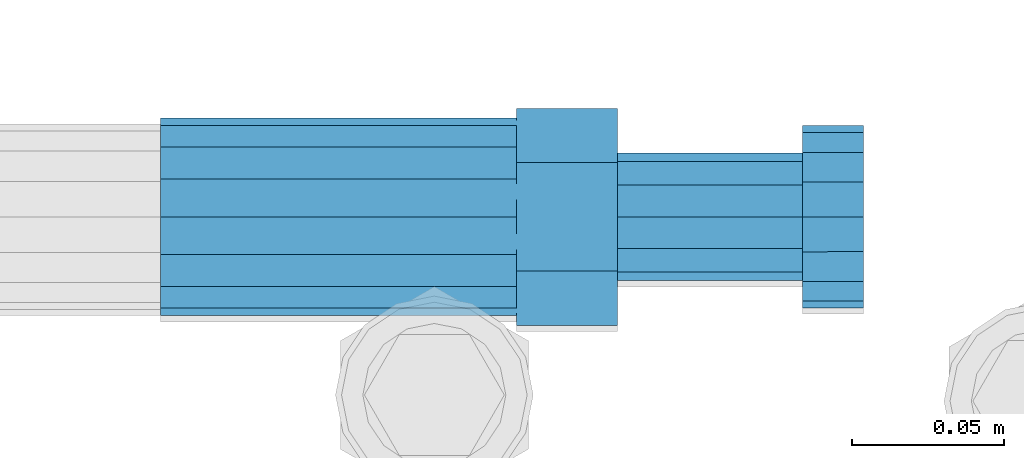
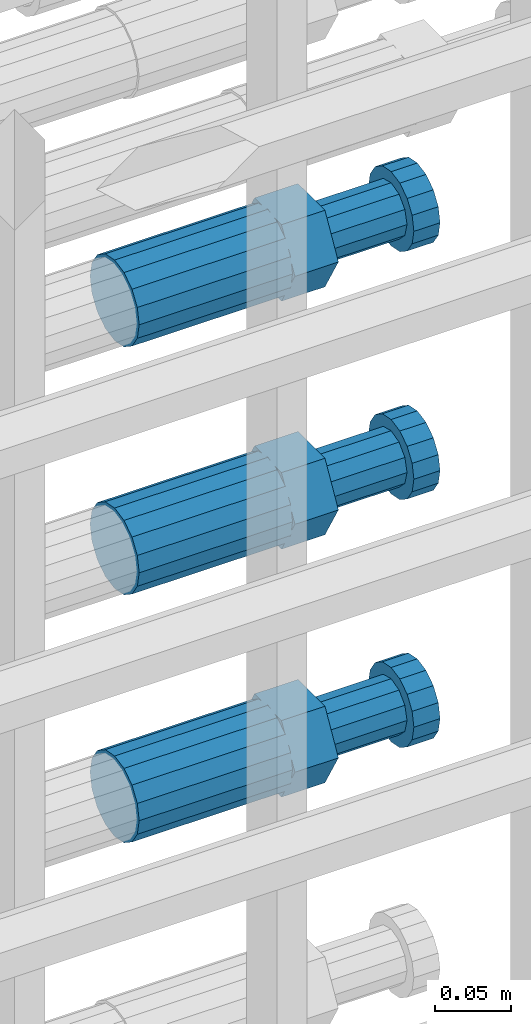
# One storey, part 100 of 119: 3 beams.
"""IFC2X3 building model written with IfcOpenShell, lengths in millimetres."""

from ifc_helpers import new_model, si_unit, frame, origin_with_axes, place, context, subcontext, project, spatial, faceted_brep, material, type_object, element, save


model = new_model("IFC2X3")

# Units and contexts
model_context = context("Model", 3, precision=1e-05, world=origin_with_axes())
body_context = subcontext(model_context, "Body", "Model", "MODEL_VIEW")
ifc_project = project(units=[si_unit("LENGTHUNIT", "METRE", prefix="MILLI"), si_unit("AREAUNIT", "SQUARE_METRE"), si_unit("VOLUMEUNIT", "CUBIC_METRE"), si_unit("MASSUNIT", "GRAM", prefix="KILO"), si_unit("TIMEUNIT", "SECOND"), si_unit("PLANEANGLEUNIT", "RADIAN"), si_unit("SOLIDANGLEUNIT", "STERADIAN"), si_unit("THERMODYNAMICTEMPERATUREUNIT", "DEGREE_CELSIUS"), si_unit("LUMINOUSINTENSITYUNIT", "LUMEN")], contexts=[model_context])

# Site, building, storey
site_placement = place(None, origin_with_axes())
site = spatial("IfcSite", under=ifc_project, at=site_placement, CompositionType="ELEMENT")
building_placement = place(site_placement, origin_with_axes())
building = spatial("IfcBuilding", under=site, at=building_placement, Name="Undefined", CompositionType="ELEMENT")
storey_placement = place(building_placement, origin_with_axes())
storey = spatial("IfcBuildingStorey", under=building, at=storey_placement, Name="Undefined", CompositionType="ELEMENT", Elevation=0.0)

# Beams
ifc_material = material(Name="STEEL/S275")
beam_type = type_object("IfcBeamType", Name="ROD65", PredefinedType="NOTDEFINED")
beam_1_placement = place(storey_placement, frame((2038739.00023304, 6205214.98994599, 21908.9894219673), z_axis=(0.0, 0.0, 1.0), x_axis=(1.0, 0.0, 0.0)))
element("IfcBeam", 1, at=beam_1_placement, inside=storey, type_object=beam_type, material=ifc_material, Name="AGB40", ObjectType="ROD65", context=body_context, shape_type="Brep", body=[
    faceted_brep([(116.999999999069, 17.8249999252148, 30.8738056446964), (116.999999998137, 22.0056957420893, 23.632628078838), (116.999999999069, 12.4372115600854, 30.0260848066173), (116.999999999069, 8.17543111252598, 30.8738056446964), (117.000000000931, -17.8250000746921, 30.8738056446964), (150.200000001118, -17.8250000723638, 30.8738056446964), (150.199999999255, 17.8249999275431, 30.8738056446964), (117.000000000931, -8.17543109622784, 30.8738056446964), (117.000000001863, -22.0056959956419, 23.6326278985034), (117.000000000931, -12.4372115437873, 30.0260848066173), (117.000000001863, -35.6500000746455, -2.18278728425503e-10), (150.200000002049, -35.6500000723172, -2.18278728425503e-10), (117.000000001863, -30.8443149488885, 8.32369080289209), (117.000000001863, -30.8443149488885, -8.32369080355784), (117.000000002794, -32.4999999918509, 0.0), (117.000000000931, -17.8250000746921, -30.873805645133), (150.200000001118, -17.8250000723638, -30.873805645133), (117.000000001863, -22.0056959961075, -23.6326278982269), (117.000000000931, -8.17543109389953, -30.873805645133), (117.000000000931, -12.4372115437873, -30.0260848066173), (116.999999999069, 17.8249999252148, -30.873805645133), (150.199999999255, 17.8249999275431, -30.873805645133), (116.999999999069, 8.17543111019768, -30.873805645133), (116.999999999069, 12.4372115600854, -30.0260848066173), (116.999999998137, 22.005695742555, -23.6326280785652), (116.999999998137, 35.6499999251682, -2.18278728425503e-10), (150.199999998324, 35.6499999277294, -2.18278728425503e-10), (116.999999998137, 30.8443150522653, -8.32369036550881), (116.999999997206, 32.5000000081491, 0.0), (116.999999998137, 30.8443150522653, 8.32369036483942), (1.86264514923096e-09, -22.9809703885112, 22.9809703885621), (1.86264514923096e-09, -30.0260848065373, 12.4372115518672), (117.000000001863, -30.0260847983882, 12.4372115518672), (117.000000001863, -22.9809703803621, 22.9809703885621), (-1.86264514923096e-09, 22.9809703885112, -22.9809703885621), (-1.86264514923096e-09, 30.0260848065373, -12.4372115518672), (116.999999998137, 30.0260848146863, -12.4372115518672), (116.999999998137, 22.9809703966603, -22.9809703885621), (1.86264514923096e-09, -30.0260848065373, -12.4372115518672), (1.86264514923096e-09, -22.9809703885112, -22.9809703885621), (117.000000001863, -22.9809703803621, -22.9809703885621), (117.000000001863, -30.0260847983882, -12.4372115518672), (9.31322574615479e-10, -12.4372115519363, 30.0260848066173), (0.0, 0.0, 32.5), (-9.31322574615479e-10, 12.4372115519363, 30.0260848066173), (-1.86264514923096e-09, 22.9809703885112, 22.9809703885621), (-1.86264514923096e-09, 30.0260848065373, 12.4372115518672), (-2.79396772384644e-09, 32.5, 0.0), (-9.31322574615479e-10, 12.4372115519363, -30.0260848066173), (0.0, 0.0, -32.5), (9.31322574615479e-10, -12.4372115519363, -30.0260848066173), (2.79396772384644e-09, -32.5, 0.0), (116.999999998137, 22.9809703966603, 22.9809703885621), (116.999999998137, 30.0260848146863, 12.4372115518672), (117.0, 8.14907252788544e-09, -32.5), (117.0, 8.14907252788544e-09, 32.5), (150.200000000186, -10.5000000959262, 18.1865334791873), (150.199999999255, -9.59262251853943e-08, 20.9999999997126), (150.199999998324, 10.4999999040738, 18.1865334791873), (150.199999997392, 18.1865333835594, 10.4999999997126), (150.199999997392, 20.9999999040738, -2.87400325760245e-10), (150.199999997392, 18.1865333835594, -10.5000000002874), (150.199999998324, 10.4999999040738, -18.1865334797621), (150.199999999255, -9.59262251853943e-08, -21.0000000002874), (150.200000000186, -10.5000000959262, -18.1865334797621), (150.200000000186, -18.1865335754119, -10.5000000002874), (150.200000001118, -21.0000000959262, -2.87400325760245e-10), (150.200000000186, -18.1865335754119, 10.4999999997126), (210.979999999516, 10.4999999082647, 18.1865334791873), (210.979999999516, -9.17352735996246e-08, 20.9999999997126), (210.979999997653, 18.1865333877504, 10.4999999997126), (210.979999997653, 20.9999999082647, -2.87400325760245e-10), (210.979999997653, 18.1865333877504, -10.5000000002874), (210.979999999516, 10.4999999082647, -18.1865334797621), (210.979999999516, -9.17352735996246e-08, -21.0000000002874), (210.979999999516, -10.5000000917353, -18.1865334797621), (210.980000000447, -18.1865335712209, -10.5000000002874), (210.980000001378, -21.0000000917353, -2.87400325760245e-10), (210.980000000447, -18.1865335712209, 10.4999999997126), (210.979999999516, -10.5000000917353, 18.1865334791873), (211.001368402503, -27.7269939335529, -11.4911163272045), (211.003082515672, -21.2238095656503, -21.2238154190527), (231.002518340945, -21.2131946226582, -21.2132004554769), (231.000804228708, -27.7163789905608, -11.4805013636287), (211.001368415542, -11.4911086384673, -27.7269970399575), (231.000804241747, -11.4804936954752, -27.7163820763781), (210.996487061493, -0.0106066407170147, -30.0106107396168), (230.995922887698, 8.30227509140968e-06, -29.999995776041), (210.98918159306, 11.4698940692469, -27.7269970332745), (230.988617419265, 11.4805090120062, -27.7163820696951), (210.980564201251, 21.2025913291145, -21.2238154067054), (230.980000027455, 21.2132062721066, -21.2132004431296), (210.971946807578, 27.7057702087332, -11.4911163110701), (230.971382633783, 27.7163851517253, -11.4805013474943), (210.964641331695, 29.9893806746695, -0.0106149565435771), (230.9640771579, 29.9999956176616, 7.03221303410828e-09), (210.959759964608, 27.7057637346443, 11.4698863966551), (230.959195790812, 27.7163786776364, 11.4805013602345), (210.958045851439, 21.2025793667417, 21.2025854885032), (230.957481677644, 21.2131943097338, 21.2132004520827), (210.959759951569, 11.4698784395587, 27.705767109408), (230.959195776843, 11.4804933823179, 27.7163820729838), (210.964641305618, -0.0106235581915826, 29.9893808090674), (230.964077131823, -8.61519947648048e-06, 29.9999957726432), (210.971946774051, -11.4911242681555, 27.7057671027251), (230.971382599324, -11.4805093251634, 27.7163820663009), (210.98056416586, -21.2238215280231, 21.2025854761559), (230.979999991134, -21.2132065852638, 21.2132004397354), (210.989181559533, -27.7270004076418, 11.4698863805206), (230.988617384806, -27.7163854646496, 11.4805013441), (210.996487035416, -30.0106108735781, -0.0106149740058754), (230.995922861621, -29.999995930586, -1.04300852399319e-08)], [[[0, 1, 2, 3]], [[4, 5, 6, 0, 3, 7]], [[8, 4, 7, 9]], [[10, 11, 5, 4, 8, 12]], [[13, 10, 12, 14]], [[15, 16, 11, 10, 13, 17]], [[18, 15, 17, 19]], [[20, 21, 16, 15, 18, 22]], [[20, 22, 23, 24]], [[25, 26, 21, 20, 24, 27]], [[25, 27, 28, 29]], [[30, 31, 32, 33]], [[34, 35, 36, 37]], [[38, 39, 40, 41]], [[31, 30, 42, 43, 44, 45, 46, 47, 35, 34, 48, 49, 50, 39, 38, 51]], [[46, 45, 52, 53]], [[28, 47, 46, 53, 29]], [[27, 36, 35, 47, 28]], [[24, 37, 36, 27]], [[23, 48, 34, 37, 24]], [[22, 54, 49, 48, 23]], [[18, 54, 22]], [[19, 50, 49, 54, 18]], [[17, 40, 39, 50, 19]], [[13, 41, 40, 17]], [[14, 51, 38, 41, 13]], [[12, 32, 31, 51, 14]], [[8, 33, 32, 12]], [[9, 42, 30, 33, 8]], [[7, 55, 43, 42, 9]], [[3, 55, 7]], [[2, 44, 43, 55, 3]], [[1, 52, 45, 44, 2]], [[29, 53, 52, 1]], [[0, 6, 26, 25, 29, 1]], [[5, 11, 16, 21, 26, 6], [56, 57, 58, 59, 60, 61, 62, 63, 64, 65, 66, 67]], [[68, 58, 57, 69]], [[70, 59, 58, 68]], [[71, 60, 59, 70]], [[72, 61, 60, 71]], [[73, 62, 61, 72]], [[74, 63, 62, 73]], [[75, 64, 63, 74]], [[76, 65, 64, 75]], [[77, 66, 65, 76]], [[78, 67, 66, 77]], [[79, 56, 67, 78]], [[69, 57, 56, 79]], [[80, 81, 82, 83]], [[81, 84, 85, 82]], [[84, 86, 87, 85]], [[86, 88, 89, 87]], [[88, 90, 91, 89]], [[90, 92, 93, 91]], [[92, 94, 95, 93]], [[94, 96, 97, 95]], [[96, 98, 99, 97]], [[98, 100, 101, 99]], [[100, 102, 103, 101]], [[102, 104, 105, 103]], [[104, 106, 107, 105]], [[106, 108, 109, 107]], [[108, 110, 111, 109]], [[82, 85, 87, 89, 91, 93, 95, 97, 99, 101, 103, 105, 107, 109, 111, 83]], [[110, 80, 83, 111]], [[108, 106, 104, 102, 100, 98, 96, 94, 92, 90, 88, 86, 84, 81, 80, 110], [78, 77, 76, 75, 74, 73, 72, 71, 70, 68, 69, 79]]]),
])
beam_2_placement = place(storey_placement, frame((2038739.00023304, 6205214.98994599, 21708.9894219673), z_axis=(0.0, 0.0, 1.0), x_axis=(1.0, 0.0, 0.0)))
element("IfcBeam", 2, at=beam_2_placement, inside=storey, type_object=beam_type, material=ifc_material, Name="AGB40", ObjectType="ROD65", context=body_context, shape_type="Brep", body=[
    faceted_brep([(116.999999999069, 17.8249999252148, 30.8738056446964), (116.999999998137, 22.0056957420893, 23.632628078838), (116.999999999069, 12.4372115600854, 30.0260848066173), (116.999999999069, 8.17543111252598, 30.8738056446964), (117.000000000931, -17.8250000746921, 30.8738056446964), (150.200000001118, -17.8250000723638, 30.8738056446964), (150.199999999255, 17.8249999275431, 30.8738056446964), (117.000000000931, -8.17543109622784, 30.8738056446964), (117.000000001863, -22.0056959956419, 23.6326278985034), (117.000000000931, -12.4372115437873, 30.0260848066173), (117.000000001863, -35.6500000746455, -2.18278728425503e-10), (150.200000002049, -35.6500000723172, -2.18278728425503e-10), (117.000000001863, -30.8443149488885, 8.32369080289209), (117.000000001863, -30.8443149488885, -8.32369080355784), (117.000000002794, -32.4999999918509, 0.0), (117.000000000931, -17.8250000746921, -30.873805645133), (150.200000001118, -17.8250000723638, -30.873805645133), (117.000000001863, -22.0056959961075, -23.6326278982269), (117.000000000931, -8.17543109389953, -30.873805645133), (117.000000000931, -12.4372115437873, -30.0260848066173), (116.999999999069, 17.8249999252148, -30.873805645133), (150.199999999255, 17.8249999275431, -30.873805645133), (116.999999999069, 8.17543111019768, -30.873805645133), (116.999999999069, 12.4372115600854, -30.0260848066173), (116.999999998137, 22.005695742555, -23.6326280785652), (116.999999998137, 35.6499999251682, -2.18278728425503e-10), (150.199999998324, 35.6499999277294, -2.18278728425503e-10), (116.999999998137, 30.8443150522653, -8.32369036550881), (116.999999997206, 32.5000000081491, 0.0), (116.999999998137, 30.8443150522653, 8.32369036483942), (1.86264514923096e-09, -22.9809703885112, 22.9809703885621), (1.86264514923096e-09, -30.0260848065373, 12.4372115518672), (117.000000001863, -30.0260847983882, 12.4372115518672), (117.000000001863, -22.9809703803621, 22.9809703885621), (-1.86264514923096e-09, 22.9809703885112, -22.9809703885621), (-1.86264514923096e-09, 30.0260848065373, -12.4372115518672), (116.999999998137, 30.0260848146863, -12.4372115518672), (116.999999998137, 22.9809703966603, -22.9809703885621), (1.86264514923096e-09, -30.0260848065373, -12.4372115518672), (1.86264514923096e-09, -22.9809703885112, -22.9809703885621), (117.000000001863, -22.9809703803621, -22.9809703885621), (117.000000001863, -30.0260847983882, -12.4372115518672), (9.31322574615479e-10, -12.4372115519363, 30.0260848066173), (0.0, 0.0, 32.5), (-9.31322574615479e-10, 12.4372115519363, 30.0260848066173), (-1.86264514923096e-09, 22.9809703885112, 22.9809703885621), (-1.86264514923096e-09, 30.0260848065373, 12.4372115518672), (-2.79396772384644e-09, 32.5, 0.0), (-9.31322574615479e-10, 12.4372115519363, -30.0260848066173), (0.0, 0.0, -32.5), (9.31322574615479e-10, -12.4372115519363, -30.0260848066173), (2.79396772384644e-09, -32.5, 0.0), (116.999999998137, 22.9809703966603, 22.9809703885621), (116.999999998137, 30.0260848146863, 12.4372115518672), (117.0, 8.14907252788544e-09, -32.5), (117.0, 8.14907252788544e-09, 32.5), (150.200000000186, -10.5000000959262, 18.1865334791873), (150.199999999255, -9.59262251853943e-08, 20.9999999997126), (150.199999998324, 10.4999999040738, 18.1865334791873), (150.199999997392, 18.1865333835594, 10.4999999997126), (150.199999997392, 20.9999999040738, -2.87400325760245e-10), (150.199999997392, 18.1865333835594, -10.5000000002874), (150.199999998324, 10.4999999040738, -18.1865334797621), (150.199999999255, -9.59262251853943e-08, -21.0000000002874), (150.200000000186, -10.5000000959262, -18.1865334797621), (150.200000000186, -18.1865335754119, -10.5000000002874), (150.200000001118, -21.0000000959262, -2.87400325760245e-10), (150.200000000186, -18.1865335754119, 10.4999999997126), (210.979999999516, 10.4999999082647, 18.1865334791873), (210.979999999516, -9.17352735996246e-08, 20.9999999997126), (210.979999997653, 18.1865333877504, 10.4999999997126), (210.979999997653, 20.9999999082647, -2.87400325760245e-10), (210.979999997653, 18.1865333877504, -10.5000000002874), (210.979999999516, 10.4999999082647, -18.1865334797621), (210.979999999516, -9.17352735996246e-08, -21.0000000002874), (210.979999999516, -10.5000000917353, -18.1865334797621), (210.980000000447, -18.1865335712209, -10.5000000002874), (210.980000001378, -21.0000000917353, -2.87400325760245e-10), (210.980000000447, -18.1865335712209, 10.4999999997126), (210.979999999516, -10.5000000917353, 18.1865334791873), (211.001368402503, -27.7269939335529, -11.4911163272045), (211.003082515672, -21.2238095656503, -21.2238154190527), (231.002518340945, -21.2131946226582, -21.2132004554769), (231.000804228708, -27.7163789905608, -11.4805013636287), (211.001368415542, -11.4911086384673, -27.7269970399575), (231.000804241747, -11.4804936954752, -27.7163820763781), (210.996487061493, -0.0106066407170147, -30.0106107396168), (230.995922887698, 8.30227509140968e-06, -29.999995776041), (210.98918159306, 11.4698940692469, -27.7269970332745), (230.988617419265, 11.4805090120062, -27.7163820696951), (210.980564201251, 21.2025913291145, -21.2238154067054), (230.980000027455, 21.2132062721066, -21.2132004431296), (210.971946807578, 27.7057702087332, -11.4911163110701), (230.971382633783, 27.7163851517253, -11.4805013474943), (210.964641331695, 29.9893806746695, -0.0106149565435771), (230.9640771579, 29.9999956176616, 7.03221303410828e-09), (210.959759964608, 27.7057637346443, 11.4698863966551), (230.959195790812, 27.7163786776364, 11.4805013602345), (210.958045851439, 21.2025793667417, 21.2025854885032), (230.957481677644, 21.2131943097338, 21.2132004520827), (210.959759951569, 11.4698784395587, 27.705767109408), (230.959195776843, 11.4804933823179, 27.7163820729838), (210.964641305618, -0.0106235581915826, 29.9893808090674), (230.964077131823, -8.61519947648048e-06, 29.9999957726432), (210.971946774051, -11.4911242681555, 27.7057671027251), (230.971382599324, -11.4805093251634, 27.7163820663009), (210.98056416586, -21.2238215280231, 21.2025854761559), (230.979999991134, -21.2132065852638, 21.2132004397354), (210.989181559533, -27.7270004076418, 11.4698863805206), (230.988617384806, -27.7163854646496, 11.4805013441), (210.996487035416, -30.0106108735781, -0.0106149740058754), (230.995922861621, -29.999995930586, -1.04300852399319e-08)], [[[0, 1, 2, 3]], [[4, 5, 6, 0, 3, 7]], [[8, 4, 7, 9]], [[10, 11, 5, 4, 8, 12]], [[13, 10, 12, 14]], [[15, 16, 11, 10, 13, 17]], [[18, 15, 17, 19]], [[20, 21, 16, 15, 18, 22]], [[20, 22, 23, 24]], [[25, 26, 21, 20, 24, 27]], [[25, 27, 28, 29]], [[30, 31, 32, 33]], [[34, 35, 36, 37]], [[38, 39, 40, 41]], [[31, 30, 42, 43, 44, 45, 46, 47, 35, 34, 48, 49, 50, 39, 38, 51]], [[46, 45, 52, 53]], [[28, 47, 46, 53, 29]], [[27, 36, 35, 47, 28]], [[24, 37, 36, 27]], [[23, 48, 34, 37, 24]], [[22, 54, 49, 48, 23]], [[18, 54, 22]], [[19, 50, 49, 54, 18]], [[17, 40, 39, 50, 19]], [[13, 41, 40, 17]], [[14, 51, 38, 41, 13]], [[12, 32, 31, 51, 14]], [[8, 33, 32, 12]], [[9, 42, 30, 33, 8]], [[7, 55, 43, 42, 9]], [[3, 55, 7]], [[2, 44, 43, 55, 3]], [[1, 52, 45, 44, 2]], [[29, 53, 52, 1]], [[0, 6, 26, 25, 29, 1]], [[5, 11, 16, 21, 26, 6], [56, 57, 58, 59, 60, 61, 62, 63, 64, 65, 66, 67]], [[68, 58, 57, 69]], [[70, 59, 58, 68]], [[71, 60, 59, 70]], [[72, 61, 60, 71]], [[73, 62, 61, 72]], [[74, 63, 62, 73]], [[75, 64, 63, 74]], [[76, 65, 64, 75]], [[77, 66, 65, 76]], [[78, 67, 66, 77]], [[79, 56, 67, 78]], [[69, 57, 56, 79]], [[80, 81, 82, 83]], [[81, 84, 85, 82]], [[84, 86, 87, 85]], [[86, 88, 89, 87]], [[88, 90, 91, 89]], [[90, 92, 93, 91]], [[92, 94, 95, 93]], [[94, 96, 97, 95]], [[96, 98, 99, 97]], [[98, 100, 101, 99]], [[100, 102, 103, 101]], [[102, 104, 105, 103]], [[104, 106, 107, 105]], [[106, 108, 109, 107]], [[108, 110, 111, 109]], [[82, 85, 87, 89, 91, 93, 95, 97, 99, 101, 103, 105, 107, 109, 111, 83]], [[110, 80, 83, 111]], [[108, 106, 104, 102, 100, 98, 96, 94, 92, 90, 88, 86, 84, 81, 80, 110], [78, 77, 76, 75, 74, 73, 72, 71, 70, 68, 69, 79]]]),
])
beam_3_placement = place(storey_placement, frame((2038739.00023304, 6205214.98994599, 21508.9894219673), z_axis=(0.0, 0.0, 1.0), x_axis=(1.0, 0.0, 0.0)))
element("IfcBeam", 3, at=beam_3_placement, inside=storey, type_object=beam_type, material=ifc_material, Name="AGB40", ObjectType="ROD65", context=body_context, shape_type="Brep", body=[
    faceted_brep([(116.999999999069, 17.8249999252148, 30.8738056446964), (116.999999998137, 22.0056957420893, 23.632628078838), (116.999999999069, 12.4372115600854, 30.0260848066173), (116.999999999069, 8.17543111252598, 30.8738056446964), (117.000000000931, -17.8250000746921, 30.8738056446964), (150.200000001118, -17.8250000723638, 30.8738056446964), (150.199999999255, 17.8249999275431, 30.8738056446964), (117.000000000931, -8.17543109622784, 30.8738056446964), (117.000000001863, -22.0056959956419, 23.6326278985034), (117.000000000931, -12.4372115437873, 30.0260848066173), (117.000000001863, -35.6500000746455, -2.18278728425503e-10), (150.200000002049, -35.6500000723172, -2.18278728425503e-10), (117.000000001863, -30.8443149488885, 8.32369080289209), (117.000000001863, -30.8443149488885, -8.32369080355784), (117.000000002794, -32.4999999918509, 0.0), (117.000000000931, -17.8250000746921, -30.873805645133), (150.200000001118, -17.8250000723638, -30.873805645133), (117.000000001863, -22.0056959961075, -23.6326278982269), (117.000000000931, -8.17543109389953, -30.873805645133), (117.000000000931, -12.4372115437873, -30.0260848066173), (116.999999999069, 17.8249999252148, -30.873805645133), (150.199999999255, 17.8249999275431, -30.873805645133), (116.999999999069, 8.17543111019768, -30.873805645133), (116.999999999069, 12.4372115600854, -30.0260848066173), (116.999999998137, 22.005695742555, -23.6326280785652), (116.999999998137, 35.6499999251682, -2.18278728425503e-10), (150.199999998324, 35.6499999277294, -2.18278728425503e-10), (116.999999998137, 30.8443150522653, -8.32369036550881), (116.999999997206, 32.5000000081491, 0.0), (116.999999998137, 30.8443150522653, 8.32369036483942), (1.86264514923096e-09, -22.9809703885112, 22.9809703885621), (1.86264514923096e-09, -30.0260848065373, 12.4372115518672), (117.000000001863, -30.0260847983882, 12.4372115518672), (117.000000001863, -22.9809703803621, 22.9809703885621), (-1.86264514923096e-09, 22.9809703885112, -22.9809703885621), (-1.86264514923096e-09, 30.0260848065373, -12.4372115518672), (116.999999998137, 30.0260848146863, -12.4372115518672), (116.999999998137, 22.9809703966603, -22.9809703885621), (1.86264514923096e-09, -30.0260848065373, -12.4372115518672), (1.86264514923096e-09, -22.9809703885112, -22.9809703885621), (117.000000001863, -22.9809703803621, -22.9809703885621), (117.000000001863, -30.0260847983882, -12.4372115518672), (9.31322574615479e-10, -12.4372115519363, 30.0260848066173), (0.0, 0.0, 32.5), (-9.31322574615479e-10, 12.4372115519363, 30.0260848066173), (-1.86264514923096e-09, 22.9809703885112, 22.9809703885621), (-1.86264514923096e-09, 30.0260848065373, 12.4372115518672), (-2.79396772384644e-09, 32.5, 0.0), (-9.31322574615479e-10, 12.4372115519363, -30.0260848066173), (0.0, 0.0, -32.5), (9.31322574615479e-10, -12.4372115519363, -30.0260848066173), (2.79396772384644e-09, -32.5, 0.0), (116.999999998137, 22.9809703966603, 22.9809703885621), (116.999999998137, 30.0260848146863, 12.4372115518672), (117.0, 8.14907252788544e-09, -32.5), (117.0, 8.14907252788544e-09, 32.5), (150.200000000186, -10.5000000959262, 18.1865334791873), (150.199999999255, -9.59262251853943e-08, 20.9999999997126), (150.199999998324, 10.4999999040738, 18.1865334791873), (150.199999997392, 18.1865333835594, 10.4999999997126), (150.199999997392, 20.9999999040738, -2.87400325760245e-10), (150.199999997392, 18.1865333835594, -10.5000000002874), (150.199999998324, 10.4999999040738, -18.1865334797621), (150.199999999255, -9.59262251853943e-08, -21.0000000002874), (150.200000000186, -10.5000000959262, -18.1865334797621), (150.200000000186, -18.1865335754119, -10.5000000002874), (150.200000001118, -21.0000000959262, -2.87400325760245e-10), (150.200000000186, -18.1865335754119, 10.4999999997126), (210.979999999516, 10.4999999082647, 18.1865334791873), (210.979999999516, -9.17352735996246e-08, 20.9999999997126), (210.979999997653, 18.1865333877504, 10.4999999997126), (210.979999997653, 20.9999999082647, -2.87400325760245e-10), (210.979999997653, 18.1865333877504, -10.5000000002874), (210.979999999516, 10.4999999082647, -18.1865334797621), (210.979999999516, -9.17352735996246e-08, -21.0000000002874), (210.979999999516, -10.5000000917353, -18.1865334797621), (210.980000000447, -18.1865335712209, -10.5000000002874), (210.980000001378, -21.0000000917353, -2.87400325760245e-10), (210.980000000447, -18.1865335712209, 10.4999999997126), (210.979999999516, -10.5000000917353, 18.1865334791873), (211.001368402503, -27.7269939335529, -11.4911163272045), (211.003082515672, -21.2238095656503, -21.2238154190527), (231.002518340945, -21.2131946226582, -21.2132004554769), (231.000804228708, -27.7163789905608, -11.4805013636287), (211.001368415542, -11.4911086384673, -27.7269970399575), (231.000804241747, -11.4804936954752, -27.7163820763781), (210.996487061493, -0.0106066407170147, -30.0106107396168), (230.995922887698, 8.30227509140968e-06, -29.999995776041), (210.98918159306, 11.4698940692469, -27.7269970332745), (230.988617419265, 11.4805090120062, -27.7163820696951), (210.980564201251, 21.2025913291145, -21.2238154067054), (230.980000027455, 21.2132062721066, -21.2132004431296), (210.971946807578, 27.7057702087332, -11.4911163110701), (230.971382633783, 27.7163851517253, -11.4805013474943), (210.964641331695, 29.9893806746695, -0.0106149565435771), (230.9640771579, 29.9999956176616, 7.03221303410828e-09), (210.959759964608, 27.7057637346443, 11.4698863966551), (230.959195790812, 27.7163786776364, 11.4805013602345), (210.958045851439, 21.2025793667417, 21.2025854885032), (230.957481677644, 21.2131943097338, 21.2132004520827), (210.959759951569, 11.4698784395587, 27.705767109408), (230.959195776843, 11.4804933823179, 27.7163820729838), (210.964641305618, -0.0106235581915826, 29.9893808090674), (230.964077131823, -8.61519947648048e-06, 29.9999957726432), (210.971946774051, -11.4911242681555, 27.7057671027251), (230.971382599324, -11.4805093251634, 27.7163820663009), (210.98056416586, -21.2238215280231, 21.2025854761559), (230.979999991134, -21.2132065852638, 21.2132004397354), (210.989181559533, -27.7270004076418, 11.4698863805206), (230.988617384806, -27.7163854646496, 11.4805013441), (210.996487035416, -30.0106108735781, -0.0106149740058754), (230.995922861621, -29.999995930586, -1.04300852399319e-08)], [[[0, 1, 2, 3]], [[4, 5, 6, 0, 3, 7]], [[8, 4, 7, 9]], [[10, 11, 5, 4, 8, 12]], [[13, 10, 12, 14]], [[15, 16, 11, 10, 13, 17]], [[18, 15, 17, 19]], [[20, 21, 16, 15, 18, 22]], [[20, 22, 23, 24]], [[25, 26, 21, 20, 24, 27]], [[25, 27, 28, 29]], [[30, 31, 32, 33]], [[34, 35, 36, 37]], [[38, 39, 40, 41]], [[31, 30, 42, 43, 44, 45, 46, 47, 35, 34, 48, 49, 50, 39, 38, 51]], [[46, 45, 52, 53]], [[28, 47, 46, 53, 29]], [[27, 36, 35, 47, 28]], [[24, 37, 36, 27]], [[23, 48, 34, 37, 24]], [[22, 54, 49, 48, 23]], [[18, 54, 22]], [[19, 50, 49, 54, 18]], [[17, 40, 39, 50, 19]], [[13, 41, 40, 17]], [[14, 51, 38, 41, 13]], [[12, 32, 31, 51, 14]], [[8, 33, 32, 12]], [[9, 42, 30, 33, 8]], [[7, 55, 43, 42, 9]], [[3, 55, 7]], [[2, 44, 43, 55, 3]], [[1, 52, 45, 44, 2]], [[29, 53, 52, 1]], [[0, 6, 26, 25, 29, 1]], [[5, 11, 16, 21, 26, 6], [56, 57, 58, 59, 60, 61, 62, 63, 64, 65, 66, 67]], [[68, 58, 57, 69]], [[70, 59, 58, 68]], [[71, 60, 59, 70]], [[72, 61, 60, 71]], [[73, 62, 61, 72]], [[74, 63, 62, 73]], [[75, 64, 63, 74]], [[76, 65, 64, 75]], [[77, 66, 65, 76]], [[78, 67, 66, 77]], [[79, 56, 67, 78]], [[69, 57, 56, 79]], [[80, 81, 82, 83]], [[81, 84, 85, 82]], [[84, 86, 87, 85]], [[86, 88, 89, 87]], [[88, 90, 91, 89]], [[90, 92, 93, 91]], [[92, 94, 95, 93]], [[94, 96, 97, 95]], [[96, 98, 99, 97]], [[98, 100, 101, 99]], [[100, 102, 103, 101]], [[102, 104, 105, 103]], [[104, 106, 107, 105]], [[106, 108, 109, 107]], [[108, 110, 111, 109]], [[82, 85, 87, 89, 91, 93, 95, 97, 99, 101, 103, 105, 107, 109, 111, 83]], [[110, 80, 83, 111]], [[108, 106, 104, 102, 100, 98, 96, 94, 92, 90, 88, 86, 84, 81, 80, 110], [78, 77, 76, 75, 74, 73, 72, 71, 70, 68, 69, 79]]]),
])

save(model, "model.ifc")
